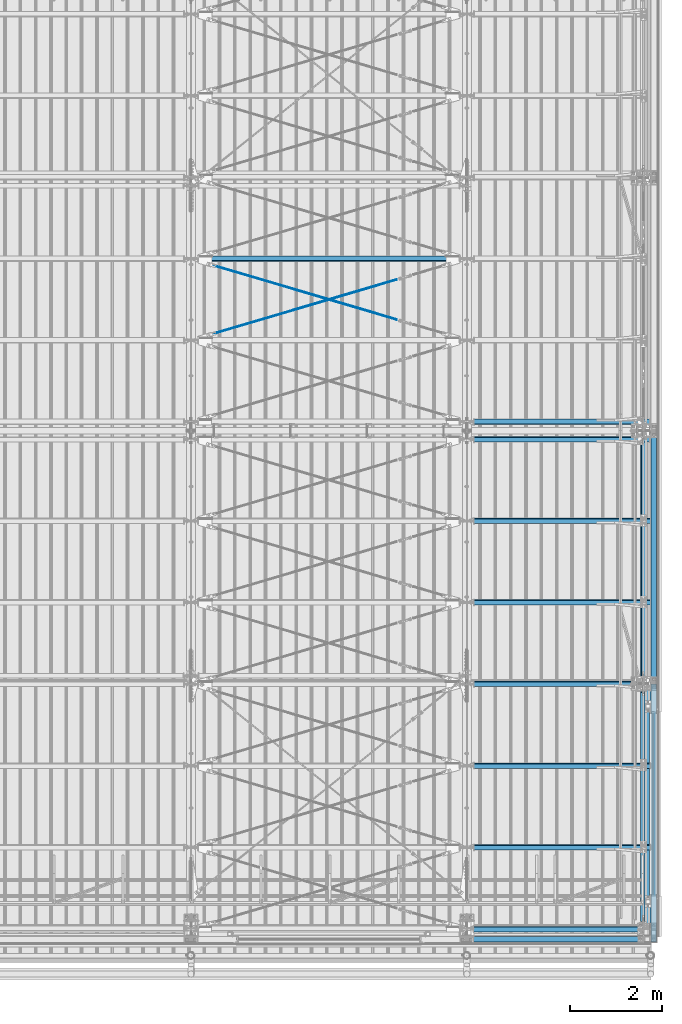
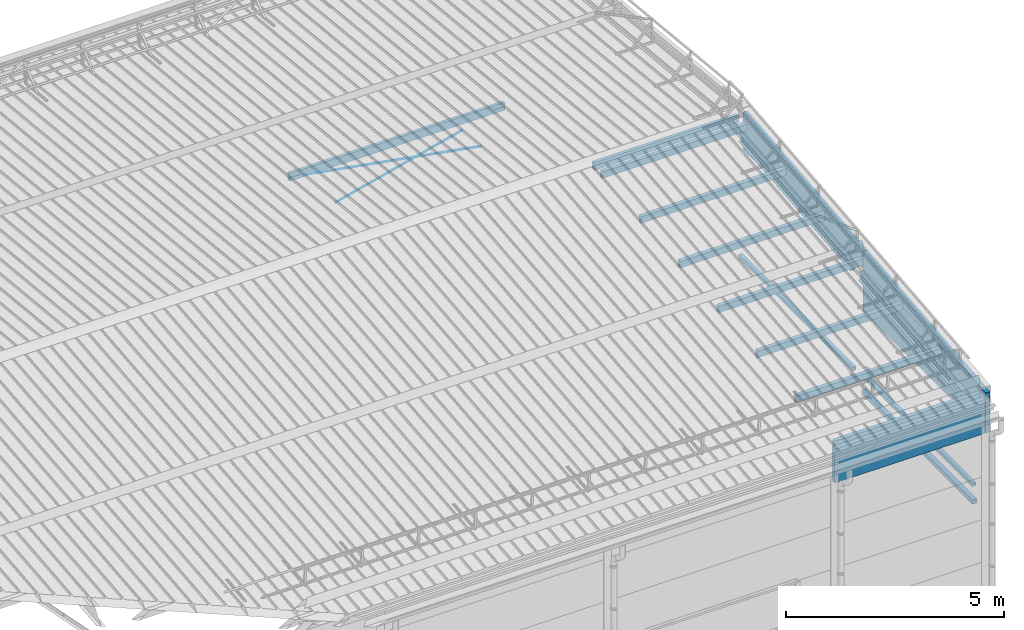
# One storey, part 282 of 709: 20 beams, 4 openings, 20 elements without a shape of their own.
"""IFC4 building model written with IfcOpenShell, lengths in millimetres."""

import ifcopenshell
import ifcopenshell.guid

model = None  # the IFC model being written
_history = None  # IfcOwnerHistory: only IFC2X3 demands one
_inside = {}  # id of a spatial element -> (the spatial element, [elements in it])
_under = {}  # id of a project, library or spatial element -> (it, [spatial elements below it])
_declared = {}  # id of a project -> (the project, [libraries it declares])
_typed = {}  # id of a type object -> (the type object, [elements of that type])
_made_of = {}  # id of a material, layer set ... -> (it, [elements and type objects made of it])


def new_model(schema):
    """Start an empty IFC model of exactly this schema.

    Asked for "IFC4X3", IfcOpenShell would pick the latest addendum, in which some entities
    have other attributes; the version numbers below select the first issue.
    IFC2X3 requires an IfcOwnerHistory on every rooted entity: one is made here for all.
    """
    global model, _history
    if schema == "IFC4X3":
        model = ifcopenshell.file(schema_version=(4, 3, 0, 0))
    else:
        model = ifcopenshell.file(schema=schema)
    _inside.clear()
    _under.clear()
    _declared.clear()
    _typed.clear()
    _made_of.clear()
    _history = None
    if model.schema == "IFC2X3":
        org = make("IfcOrganization", Name="unknown")
        user = make(
            "IfcPersonAndOrganization",
            ThePerson=make("IfcPerson", FamilyName="unknown"),
            TheOrganization=org,
        )
        app = make(
            "IfcApplication",
            ApplicationDeveloper=org,
            Version="unknown",
            ApplicationFullName="unknown",
            ApplicationIdentifier="unknown",
        )
        _history = make(
            "IfcOwnerHistory",
            OwningUser=user,
            OwningApplication=app,
            ChangeAction="ADDED",
            CreationDate=0,
        )
    return model


def make(cls, **values):
    """One entity of the class cls with the attributes given. An attribute that is None is left unset."""
    return model.create_entity(
        cls, **{name: value for name, value in values.items() if value is not None}
    )


def rooted(cls, **values):
    """An entity with a GlobalId (a new one), such as an element, a storey or a relation."""
    return make(cls, GlobalId=ifcopenshell.guid.new(), OwnerHistory=_history, **values)


def si_unit(unit_type, name, prefix=None):
    """IfcSIUnit, for example si_unit("LENGTHUNIT", "METRE", prefix="MILLI")."""
    return make("IfcSIUnit", UnitType=unit_type, Prefix=prefix, Name=name)


def assignment(units):
    """IfcUnitAssignment: the units of a project."""
    return None if units is None else make("IfcUnitAssignment", Units=units)


def point(xyz):
    """IfcCartesianPoint."""
    return None if xyz is None else make("IfcCartesianPoint", Coordinates=xyz)


def direction(xyz):
    """IfcDirection."""
    return None if xyz is None else make("IfcDirection", DirectionRatios=xyz)


def frame(location, z_axis=None, x_axis=None):
    """IfcAxis2Placement3D, a coordinate frame: its origin and axes. An axis left out is left unset."""
    return make(
        "IfcAxis2Placement3D",
        Location=point(location),
        Axis=direction(z_axis),
        RefDirection=direction(x_axis),
    )


def origin_with_axes():
    """The frame at (0, 0, 0) with the z axis (0, 0, 1) and the x axis (1, 0, 0) written out."""
    return frame((0.0, 0.0, 0.0), z_axis=(0.0, 0.0, 1.0), x_axis=(1.0, 0.0, 0.0))


def place(relative_to, where):
    """IfcLocalPlacement: puts the frame where relative to a parent placement (None: the world)."""
    return make(
        "IfcLocalPlacement", PlacementRelTo=relative_to, RelativePlacement=where
    )


def context(
    kind, dimensions, precision=None, world=None, true_north=None, identifier=None
):
    """IfcGeometricRepresentationContext, for example the 3D "Model" context."""
    return make(
        "IfcGeometricRepresentationContext",
        ContextIdentifier=identifier,
        ContextType=kind,
        CoordinateSpaceDimension=dimensions,
        Precision=precision,
        WorldCoordinateSystem=world,
        TrueNorth=true_north,
    )


def subcontext(parent, identifier, kind, view, scale=None):
    """IfcGeometricRepresentationSubContext, for example "Body" below "Model"."""
    return make(
        "IfcGeometricRepresentationSubContext",
        ContextIdentifier=identifier,
        ContextType=kind,
        ParentContext=parent,
        TargetScale=scale,
        TargetView=view,
    )


def project(units=None, contexts=None):
    """IfcProject with its units and contexts."""
    return rooted(
        "IfcProject",
        Name="project",
        RepresentationContexts=contexts,
        UnitsInContext=assignment(units),
    )


def spatial(cls, under=None, at=None, **own):
    """A site, building, storey or space (cls), placed at a placement, below another one or the project."""
    s = rooted(cls, ObjectPlacement=at, **own)
    if under is not None:
        _under.setdefault(under.id(), (under, []))[1].append(s)
    return s


def point_list(points):
    """IfcCartesianPointList2D or 3D."""
    cls = (
        "IfcCartesianPointList2D" if len(points[0]) == 2 else "IfcCartesianPointList3D"
    )
    return make(cls, CoordList=points)


def line(*indices):
    """IfcLineIndex: a straight run through numbered points of an indexed curve."""
    return model.create_entity("IfcLineIndex", indices)


def indexed_curve(points, segments=None, self_intersect=None):
    """IfcIndexedPolyCurve: lines and arcs through numbered points (the first is 1)."""
    return make(
        "IfcIndexedPolyCurve",
        Points=point_list(points),
        Segments=segments,
        SelfIntersect=self_intersect,
    )


def outline(outer, holes=None, kind="AREA"):
    """IfcArbitraryClosedProfileDef: a profile drawn as a closed curve; with holes, ...WithVoids."""
    if holes is None:
        return make("IfcArbitraryClosedProfileDef", ProfileType=kind, OuterCurve=outer)
    return make(
        "IfcArbitraryProfileDefWithVoids",
        ProfileType=kind,
        OuterCurve=outer,
        InnerCurves=holes,
    )


def extrude(swept, where, along, depth):
    """IfcExtrudedAreaSolid: the profile swept, set in the frame where, extruded along a direction by depth."""
    return make(
        "IfcExtrudedAreaSolid",
        SweptArea=swept,
        Position=where,
        ExtrudedDirection=direction(along),
        Depth=depth,
    )


def polygons(points, faces, closed=None, point_numbers=None):
    """IfcPolygonalFaceSet: a face is its outer loop, then its inner loops; points numbered from 1."""
    made = []
    for loops in faces:
        if len(loops) == 1:
            made.append(make("IfcIndexedPolygonalFace", CoordIndex=loops[0]))
        else:
            made.append(
                make(
                    "IfcIndexedPolygonalFaceWithVoids",
                    CoordIndex=loops[0],
                    InnerCoordIndices=loops[1:],
                )
            )
    return make(
        "IfcPolygonalFaceSet",
        Coordinates=point_list(points),
        Closed=closed,
        Faces=made,
        PnIndex=point_numbers,
    )


def shape(context_of_items, identifier, shape_type, items):
    """IfcShapeRepresentation: the items that make up one representation, for example the "Body"."""
    return make(
        "IfcShapeRepresentation",
        ContextOfItems=context_of_items,
        RepresentationIdentifier=identifier,
        RepresentationType=shape_type,
        Items=items,
    )


def material(Name=None, Category=None):
    """IfcMaterial."""
    return make("IfcMaterial", Name=Name, Category=Category)


def made_of(thing, what):
    """Note that an element or type object is made of a material, layer set ...; save() writes the relation."""
    if what is not None:
        _made_of.setdefault(what.id(), (what, []))[1].append(thing)
    return thing


def element(
    cls,
    number,
    at=None,
    inside=None,
    cuts=None,
    type_object=None,
    material=None,
    context=None,
    identifier="Body",
    shape_type=None,
    held_by="IfcProductDefinitionShape",
    body=None,
    shapes=None,
    **own,
):
    """One element of the class cls, such as IfcWall. Its Tag is "e" and its number.

    at: its placement. inside: the storey or other place that contains it. cuts: it is an
    opening in that element (IfcRelVoidsElement). A single representation is given by context,
    identifier, shape_type and body (its items); several are given by shapes. held_by: the class
    of the entity that holds the representations. save() writes the other relations.
    """
    e = rooted(cls, Tag="e%d" % number, ObjectPlacement=at, **own)
    if body is not None:
        shapes = [shape(context, identifier, shape_type, body)]
    if shapes is not None:
        e.Representation = make(held_by, Representations=shapes)
    if inside is not None:
        _inside.setdefault(inside.id(), (inside, []))[1].append(e)
    if cuts is not None:
        rooted(
            "IfcRelVoidsElement", RelatingBuildingElement=cuts, RelatedOpeningElement=e
        )
    if type_object is not None:
        _typed.setdefault(type_object.id(), (type_object, []))[1].append(e)
    return made_of(e, material)


def aggregate(whole, parts):
    """IfcRelAggregates: a whole, such as a stair, and the parts it consists of."""
    return rooted("IfcRelAggregates", RelatingObject=whole, RelatedObjects=parts)


def save(model, path):
    """Write the relations noted so far, then the file.

    IfcRelAggregates (storeys below a building ...), IfcRelContainedInSpatialStructure (elements
    in a storey), IfcRelDefinesByType, IfcRelAssociatesMaterial and IfcRelDeclares: one each for
    every whole, place, type object, material and project.
    """
    for whole, parts in _under.values():
        aggregate(whole, parts)
    for where, things in _inside.values():
        rooted(
            "IfcRelContainedInSpatialStructure",
            RelatedElements=things,
            RelatingStructure=where,
        )
    for kind, things in _typed.values():
        rooted("IfcRelDefinesByType", RelatedObjects=things, RelatingType=kind)
    for what, things in _made_of.values():
        rooted("IfcRelAssociatesMaterial", RelatedObjects=things, RelatingMaterial=what)
    for by, libraries in _declared.values():
        rooted("IfcRelDeclares", RelatingContext=by, RelatedDefinitions=libraries)
    model.write(path)


model = new_model("IFC4")

# Units and contexts
model_context = context("Model", 3, precision=0.2, world=origin_with_axes(), true_north=direction((0.0, 1.0)))
body_context = subcontext(model_context, "Body", "Model", "MODEL_VIEW")
reference_context = subcontext(model_context, "Reference", "Model", "MODEL_VIEW")
ifc_project = project(units=[si_unit("LENGTHUNIT", "METRE", prefix="MILLI"), si_unit("AREAUNIT", "SQUARE_METRE"), si_unit("VOLUMEUNIT", "CUBIC_METRE"), si_unit("MASSUNIT", "GRAM", prefix="KILO"), si_unit("TIMEUNIT", "SECOND"), si_unit("PLANEANGLEUNIT", "RADIAN"), si_unit("SOLIDANGLEUNIT", "STERADIAN"), si_unit("THERMODYNAMICTEMPERATUREUNIT", "DEGREE_CELSIUS"), si_unit("LUMINOUSINTENSITYUNIT", "LUMEN")], contexts=[model_context])

# Site, building, storey
site_placement = place(None, origin_with_axes())
site = spatial("IfcSite", under=ifc_project, at=site_placement, CompositionType="ELEMENT")
building_placement = place(site_placement, origin_with_axes())
building = spatial("IfcBuilding", under=site, at=building_placement, Name="Undefined", CompositionType="ELEMENT")
storey_placement = place(building_placement, origin_with_axes())
storey = spatial("IfcBuildingStorey", under=building, at=storey_placement, Name="Undefined", CompositionType="ELEMENT", Elevation=0.0)

# Assembly, beam
assembly_1_placement = place(storey_placement, frame((49837.5, 346.0, 6929.907), z_axis=(1.0, 0.0, 0.0), x_axis=(0.0, 0.9950371902, 0.099503719)))
assembly_1 = element("IfcElementAssembly", 1, at=assembly_1_placement, inside=storey)
ifc_material_1 = material(Name="C255-4", Category="STEEL")
beam_1_placement = place(assembly_1_placement, origin_with_axes())
beam_1 = element("IfcBeam", 2, at=beam_1_placement, material=ifc_material_1, ObjectType="451", context=body_context, shape_type="Tessellation", body=[
    polygons([(-15.12818, -124.0, -62.0), (-15.12818, -116.0, -62.0), (4996.83432, -116.0, -62.0), (4996.83432, -124.0, -62.0), (-15.12818, -116.0, -2.5), (4996.83432, -116.0, -2.5), (-15.12818, 116.0, -2.5), (4996.83432, 116.0, -2.5), (-15.12818, 116.0, -62.0), (4996.83432, 116.0, -62.0), (-15.12818, 124.0, -62.0), (4996.83432, 124.0, -62.0), (-15.12818, 124.0, 62.0), (4996.83432, 124.0, 62.0), (-15.12818, 116.0, 62.0), (4996.83432, 116.0, 62.0), (-15.12818, 116.0, 2.5), (4996.83432, 116.0, 2.5), (-15.12818, -116.0, 2.5), (4996.83432, -116.0, 2.5), (-15.12818, -116.0, 62.0), (4996.83432, -116.0, 62.0), (-15.12818, -124.0, 62.0), (4996.83432, -124.0, 62.0)], [[[1, 2, 3, 4]], [[2, 5, 6, 3]], [[5, 7, 8, 6]], [[7, 9, 10, 8]], [[9, 11, 12, 10]], [[11, 13, 14, 12]], [[13, 15, 16, 14]], [[15, 17, 18, 16]], [[17, 19, 20, 18]], [[19, 21, 22, 20]], [[21, 23, 24, 22]], [[23, 1, 4, 24]], [[6, 8, 10, 12, 14, 16, 18, 20, 22, 24, 4, 3]], [[23, 21, 19, 17, 15, 13, 11, 9, 7, 5, 2, 1]]], closed=True),
])
aggregate(assembly_1, [beam_1])

assembly_2_placement = place(storey_placement, frame((49837.5, 5500.0, 7445.307), z_axis=(1.0, 0.0, 0.0), x_axis=(0.0, 0.9950371902, 0.099503719)))
assembly_2 = element("IfcElementAssembly", 3, at=assembly_2_placement, inside=storey)
beam_2_placement = place(assembly_2_placement, origin_with_axes())
beam_2 = element("IfcBeam", 4, at=beam_2_placement, material=ifc_material_1, ObjectType="452", context=body_context, shape_type="Tessellation", body=[
    polygons([(5323.56002, 116.0, 2.5), (5323.56002, -116.0, 2.5), (5323.56002, -116.0, 62.0), (5323.56002, -124.0, 62.0), (5323.56002, -124.0, -62.0), (5323.56002, -116.0, -62.0), (5323.56002, -116.0, -2.5), (5323.56002, 116.0, -2.5), (5323.56002, 116.0, -62.0), (5323.56002, 124.0, -62.0), (5323.56002, 124.0, 62.0), (5323.56002, 116.0, 62.0), (166.87157, 124.0, 62.0), (166.87157, 116.0, 62.0), (166.87157, 116.0, 2.5), (166.87157, -116.0, 2.5), (166.87157, -116.0, 62.0), (166.87157, -124.0, 62.0), (166.87157, -124.0, -62.0), (166.87157, -116.0, -62.0), (166.87157, -116.0, -2.5), (166.87157, 116.0, -2.5), (166.87157, 116.0, -62.0), (166.87157, 124.0, -62.0)], [[[1, 2, 3, 4, 5, 6, 7, 8, 9, 10, 11, 12]], [[12, 11, 13, 14]], [[1, 12, 14, 15]], [[2, 1, 15, 16]], [[3, 2, 16, 17]], [[4, 3, 17, 18]], [[5, 4, 18, 19]], [[6, 5, 19, 20]], [[7, 6, 20, 21]], [[8, 7, 21, 22]], [[9, 8, 22, 23]], [[10, 9, 23, 24]], [[11, 10, 24, 13]], [[23, 22, 21, 20, 19, 18, 17, 16, 15, 14, 13, 24]]], closed=True),
])
aggregate(assembly_2, [beam_2])

assembly_3_placement = place(storey_placement, frame((49920.0, 80.0, 4610.0), z_axis=(0.0, 0.0, -1.0), x_axis=(0.0, 1.0, 0.0)))
assembly_3 = element("IfcElementAssembly", 5, at=assembly_3_placement, inside=storey)
ifc_material_2 = material(Name="C355", Category="STEEL")
beam_3_placement = place(assembly_3_placement, origin_with_axes())
beam_3 = element("IfcBeam", 6, at=beam_3_placement, material=ifc_material_2, ObjectType="494", context=body_context, shape_type="Tessellation", body=[
    polygons([(5277.5, 50.0, 50.0), (5277.5, 50.0, -50.0), (198.0, 50.0, -50.0), (198.0, 50.0, 50.0), (5277.5, -50.0, 50.0), (198.0, -50.0, 50.0), (5277.5, -50.0, -50.0), (198.0, -50.0, -50.0), (5277.5, 47.0, -47.0), (5277.5, 47.0, 47.0), (198.0, 47.0, 47.0), (198.0, 47.0, -47.0), (5277.5, -47.0, -47.0), (198.0, -47.0, -47.0), (5277.5, -47.0, 47.0), (198.0, -47.0, 47.0)], [[[1, 2, 3, 4]], [[5, 1, 4, 6]], [[7, 5, 6, 8]], [[2, 7, 8, 3]], [[1, 5, 7, 2], [10, 9, 13, 15]], [[9, 10, 11, 12]], [[13, 9, 12, 14]], [[15, 13, 14, 16]], [[10, 15, 16, 11]], [[8, 6, 4, 3], [14, 12, 11, 16]]], closed=True),
])
aggregate(assembly_3, [beam_3])

assembly_4_placement = place(storey_placement, frame((49940.0, 80.0, 4120.0), z_axis=(0.0, 0.0, -1.0), x_axis=(0.0, 1.0, 0.0)))
assembly_4 = element("IfcElementAssembly", 7, at=assembly_4_placement, inside=storey)
ifc_material_3 = material(Name="C255", Category="STEEL")
beam_4_placement = place(assembly_4_placement, origin_with_axes())
beam_4 = element("IfcBeam", 8, at=beam_4_placement, material=ifc_material_3, ObjectType="531", context=body_context, shape_type="Tessellation", body=[
    polygons([(5277.5, 60.0, 60.0), (5277.5, 60.0, -60.0), (198.0, 60.0, -60.0), (198.0, 60.0, 60.0), (5277.5, -60.0, 60.0), (198.0, -60.0, 60.0), (5277.5, -60.0, -60.0), (198.0, -60.0, -60.0), (5277.5, 56.0, -56.0), (5277.5, 56.0, 56.0), (198.0, 56.0, 56.0), (198.0, 56.0, -56.0), (5277.5, -56.0, -56.0), (198.0, -56.0, -56.0), (5277.5, -56.0, 56.0), (198.0, -56.0, 56.0)], [[[1, 2, 3, 4]], [[5, 1, 4, 6]], [[7, 5, 6, 8]], [[2, 7, 8, 3]], [[1, 5, 7, 2], [10, 9, 13, 15]], [[9, 10, 11, 12]], [[13, 9, 12, 14]], [[15, 13, 14, 16]], [[10, 15, 16, 11]], [[8, 6, 4, 3], [14, 12, 11, 16]]], closed=True),
])
aggregate(assembly_4, [beam_4])

assembly_5_placement = place(storey_placement, frame((49851.0, 5500.0, 4610.0), z_axis=(0.0, 0.0, -1.0), x_axis=(0.0, 1.0, 0.0)))
assembly_5 = element("IfcElementAssembly", 9, at=assembly_5_placement, inside=storey)
beam_5_placement = place(assembly_5_placement, origin_with_axes())
beam_5 = element("IfcBeam", 10, at=beam_5_placement, material=ifc_material_2, ObjectType="512", context=body_context, shape_type="Tessellation", body=[
    polygons([(142.5, -47.0, -47.0), (142.5, -47.0, 47.0), (5357.5, -47.0, 47.0), (5357.5, -47.0, -47.0), (142.5, 47.0, 47.0), (5357.5, 47.0, 47.0), (142.5, 47.0, -47.0), (5357.5, 47.0, -47.0), (142.5, -50.0, -50.0), (142.5, 50.0, -50.0), (5357.5, 50.0, -50.0), (5357.5, -50.0, -50.0), (142.5, 50.0, 50.0), (5357.5, 50.0, 50.0), (142.5, -50.0, 50.0), (5357.5, -50.0, 50.0)], [[[1, 2, 3, 4]], [[2, 5, 6, 3]], [[5, 7, 8, 6]], [[7, 1, 4, 8]], [[9, 10, 11, 12]], [[10, 13, 14, 11]], [[13, 15, 16, 14]], [[15, 9, 12, 16]], [[14, 16, 12, 11], [6, 8, 4, 3]], [[15, 13, 10, 9], [7, 5, 2, 1]]], closed=True),
])
aggregate(assembly_5, [beam_5])

# Assembly, beam, voiding feature
assembly_6_placement = place(storey_placement, frame((40000.0, 12964.14591, 8040.08943), z_axis=(0.2847296511, -0.9538504697, 0.095385047), x_axis=(0.9586078582, 0.2833165921, -0.028331659)))
assembly_6 = element("IfcElementAssembly", 11, at=assembly_6_placement, inside=storey)
ifc_material_4 = material(Name="C355-5", Category="STEEL")
beam_6_placement = place(assembly_6_placement, origin_with_axes())
beam_6 = element("IfcBeam", 12, at=beam_6_placement, material=ifc_material_4, ObjectType="572", context=body_context, shape_type="Tessellation", body=[
    polygons([(4849.07659, 7.36122, 4.25), (4849.07659, 6.01041, 6.01041), (4849.07659, 4.25, 7.36122), (4849.07659, 2.19996, 8.21037), (4849.07659, 0.0, 8.5), (4849.07659, -2.19996, 8.21037), (4849.07659, -4.25, 7.36122), (4849.07659, -6.01041, 6.01041), (4849.07659, -7.36121, 4.25), (4849.07659, -8.21037, 2.19996), (4849.07659, -8.5, 0.0), (4849.07659, -8.21037, -2.19996), (4849.07659, -7.36121, -4.25), (4849.07659, -6.01041, -6.01041), (4849.07659, -4.25, -7.36122), (4849.07659, -2.19996, -8.21037), (4849.07659, 0.0, -8.5), (4849.07659, 2.19996, -8.21037), (4849.07659, 4.25, -7.36122), (4849.07659, 6.01041, -6.01041), (4849.07659, 7.36122, -4.25), (4849.07659, 8.21037, -2.19996), (4849.07659, 8.5, 0.0), (4849.07659, 8.21037, 2.19996), (4669.07659, 8.21037, 2.19996), (4669.07659, 7.36122, 4.25), (4669.07659, 6.01041, 6.01041), (4669.07659, 4.25, 7.36122), (4669.07659, 2.19996, 8.21037), (4669.07659, 0.0, 8.5), (4669.07659, -2.19996, 8.21037), (4669.07659, -4.25, 7.36122), (4669.07659, -6.01041, 6.01041), (4669.07659, -7.36121, 4.25), (4669.07659, -8.21037, 2.19996), (4669.07659, -8.5, 0.0), (4669.07659, -8.21037, -2.19996), (4669.07659, -7.36121, -4.25), (4669.07659, -6.01041, -6.01041), (4669.07659, -4.25, -7.36122), (4669.07659, -2.19996, -8.21037), (4669.07659, 0.0, -8.5), (4669.07659, 2.19996, -8.21037), (4669.07659, 4.25, -7.36122), (4669.07659, 6.01041, -6.01041), (4669.07659, 7.36122, -4.25), (4669.07659, 8.21037, -2.19996), (4669.07659, 8.5, 0.0), (4669.07659, 10.0, 0.0), (4669.07659, 9.65926, 2.58819), (4669.07659, 8.66025, 5.0), (4669.07659, 7.07107, 7.07107), (4669.07659, 5.0, 8.66025), (4669.07659, 2.58819, 9.65926), (4669.07659, 0.0, 10.0), (4669.07659, -2.58819, 9.65926), (4669.07659, -5.0, 8.66025), (4669.07659, -7.07107, 7.07107), (4669.07659, -8.66025, 5.0), (4669.07659, -9.65926, 2.58819), (4669.07659, -10.0, 0.0), (4669.07659, -9.65926, -2.58819), (4669.07659, -8.66025, -5.0), (4669.07659, -7.07107, -7.07107), (4669.07659, -5.0, -8.66025), (4669.07659, -2.58819, -9.65926), (4669.07659, 0.0, -10.0), (4669.07659, 2.58819, -9.65926), (4669.07659, 5.0, -8.66025), (4669.07659, 7.07107, -7.07107), (4669.07659, 8.66025, -5.0), (4669.07659, 9.65926, -2.58819), (483.68279, 2.58819, 9.65926), (483.68279, 5.0, 8.66025), (483.68279, 7.07107, 7.07107), (483.68279, 8.66025, 5.0), (483.68279, 9.65926, 2.58819), (483.68279, 10.0, 0.0), (483.68279, 9.65926, -2.58819), (483.68279, 8.66025, -5.0), (483.68279, 7.07107, -7.07107), (483.68279, 5.0, -8.66025), (483.68279, 2.58819, -9.65926), (483.68279, 0.0, -10.0), (483.68279, -2.58819, -9.65926), (483.68279, -5.0, -8.66025), (483.68279, -7.07107, -7.07107), (483.68279, -8.66025, -5.0), (483.68279, -9.65926, -2.58819), (483.68279, -10.0, 0.0), (483.68279, -9.65926, 2.58819), (483.68279, -8.66025, 5.0), (483.68279, -7.07107, 7.07107), (483.68279, -5.0, 8.66025), (483.68279, -2.58819, 9.65926), (483.68279, 0.0, 10.0)], [[[1, 2, 3, 4, 5, 6, 7, 8, 9, 10, 11, 12, 13, 14, 15, 16, 17, 18, 19, 20, 21, 22, 23, 24]], [[24, 25, 26, 1]], [[1, 26, 27, 2]], [[2, 27, 28, 3]], [[3, 28, 29, 4]], [[4, 29, 30, 5]], [[5, 30, 31, 6]], [[6, 31, 32, 7]], [[7, 32, 33, 8]], [[8, 33, 34, 9]], [[9, 34, 35, 10]], [[10, 35, 36, 11]], [[11, 36, 37, 12]], [[12, 37, 38, 13]], [[13, 38, 39, 14]], [[14, 39, 40, 15]], [[15, 40, 41, 16]], [[16, 41, 42, 17]], [[17, 42, 43, 18]], [[18, 43, 44, 19]], [[19, 44, 45, 20]], [[20, 45, 46, 21]], [[21, 46, 47, 22]], [[22, 47, 48, 23]], [[23, 48, 25, 24]], [[49, 50, 51, 52, 53, 54, 55, 56, 57, 58, 59, 60, 61, 62, 63, 64, 65, 66, 67, 68, 69, 70, 71, 72], [47, 46, 45, 44, 43, 42, 41, 40, 39, 38, 37, 36, 35, 34, 33, 32, 31, 30, 29, 28, 27, 26, 25, 48]], [[73, 74, 75, 76, 77, 78, 79, 80, 81, 82, 83, 84, 85, 86, 87, 88, 89, 90, 91, 92, 93, 94, 95, 96]], [[79, 78, 49, 72]], [[80, 79, 72, 71]], [[81, 80, 71, 70]], [[82, 81, 70, 69]], [[83, 82, 69, 68]], [[84, 83, 68, 67]], [[85, 84, 67, 66]], [[86, 85, 66, 65]], [[87, 86, 65, 64]], [[88, 87, 64, 63]], [[89, 88, 63, 62]], [[90, 89, 62, 61]], [[91, 90, 61, 60]], [[92, 91, 60, 59]], [[93, 92, 59, 58]], [[94, 93, 58, 57]], [[95, 94, 57, 56]], [[96, 95, 56, 55]], [[73, 96, 55, 54]], [[74, 73, 54, 53]], [[75, 74, 53, 52]], [[76, 75, 52, 51]], [[77, 76, 51, 50]], [[78, 77, 50, 49]]], closed=True),
])
voiding_feature_1_placement = place(beam_6_placement, frame((4849.07659, 0.0, 0.0), z_axis=(0.0, 1.0, 0.0), x_axis=(-1.0, 0.0, 0.0)))
element("IfcVoidingFeature", 13, at=voiding_feature_1_placement, cuts=beam_6, PredefinedType="HOLE", context=reference_context, identifier="Reference", shape_type="SolidModel", body=[
    extrude(outline(indexed_curve([(10.5, 0.0), (10.14222, 2.7176), (9.09327, 5.25), (7.42462, 7.42462), (5.25, 9.09327), (2.7176, 10.14222), (0.0, 10.5), (-2.7176, 10.14222), (-5.25, 9.09327), (-7.42462, 7.42462), (-9.09327, 5.25), (-10.14222, 2.7176), (-10.5, 0.0), (-10.14222, -2.7176), (-9.09327, -5.25), (-7.42462, -7.42462), (-5.25, -9.09327), (-2.7176, -10.14222), (0.0, -10.5), (2.7176, -10.14222), (5.25, -9.09327), (7.42462, -7.42462), (9.09327, -5.25), (10.14222, -2.7176)], segments=[line(1, 2, 3, 4, 5, 6, 7, 8, 9, 10, 11, 12, 13, 14, 15, 16, 17, 18, 19, 20, 21, 22, 23, 24, 1)])), frame((0.0, 0.0, 0.0), z_axis=(-1.0, 0.0, 0.0), x_axis=(0.0, 0.0, 1.0)), (0.0, 0.0, -1.0), 180.0),
])
aggregate(assembly_6, [beam_6])

assembly_7_placement = place(storey_placement, frame((40000.0, 14737.44615, 7862.7594), z_axis=(-0.2847296511, -0.9538504697, 0.095385047), x_axis=(0.9586078582, -0.2833165921, 0.028331659)))
assembly_7 = element("IfcElementAssembly", 14, at=assembly_7_placement, inside=storey)
beam_7_placement = place(assembly_7_placement, origin_with_axes())
beam_7 = element("IfcBeam", 15, at=beam_7_placement, material=ifc_material_4, ObjectType="572", context=body_context, shape_type="Tessellation", body=[
    polygons([(4849.07659, 7.36122, 4.25), (4849.07659, 6.01041, 6.01041), (4849.07659, 4.25, 7.36122), (4849.07659, 2.19996, 8.21037), (4849.07659, 0.0, 8.5), (4849.07659, -2.19996, 8.21037), (4849.07659, -4.25, 7.36122), (4849.07659, -6.01041, 6.01041), (4849.07659, -7.36121, 4.25), (4849.07659, -8.21037, 2.19996), (4849.07659, -8.5, 0.0), (4849.07659, -8.21037, -2.19996), (4849.07659, -7.36121, -4.25), (4849.07659, -6.01041, -6.01041), (4849.07659, -4.25, -7.36122), (4849.07659, -2.19996, -8.21037), (4849.07659, 0.0, -8.5), (4849.07659, 2.19996, -8.21037), (4849.07659, 4.25, -7.36122), (4849.07659, 6.01041, -6.01041), (4849.07659, 7.36122, -4.25), (4849.07659, 8.21037, -2.19996), (4849.07659, 8.5, 0.0), (4849.07659, 8.21037, 2.19996), (4669.07659, 8.21037, 2.19996), (4669.07659, 7.36122, 4.25), (4669.07659, 6.01041, 6.01041), (4669.07659, 4.25, 7.36122), (4669.07659, 2.19996, 8.21037), (4669.07659, 0.0, 8.5), (4669.07659, -2.19996, 8.21037), (4669.07659, -4.25, 7.36122), (4669.07659, -6.01041, 6.01041), (4669.07659, -7.36121, 4.25), (4669.07659, -8.21037, 2.19996), (4669.07659, -8.5, 0.0), (4669.07659, -8.21037, -2.19996), (4669.07659, -7.36121, -4.25), (4669.07659, -6.01041, -6.01041), (4669.07659, -4.25, -7.36122), (4669.07659, -2.19996, -8.21037), (4669.07659, 0.0, -8.5), (4669.07659, 2.19996, -8.21037), (4669.07659, 4.25, -7.36122), (4669.07659, 6.01041, -6.01041), (4669.07659, 7.36122, -4.25), (4669.07659, 8.21037, -2.19996), (4669.07659, 8.5, 0.0), (4669.07659, 10.0, 0.0), (4669.07659, 9.65926, 2.58819), (4669.07659, 8.66025, 5.0), (4669.07659, 7.07107, 7.07107), (4669.07659, 5.0, 8.66025), (4669.07659, 2.58819, 9.65926), (4669.07659, 0.0, 10.0), (4669.07659, -2.58819, 9.65926), (4669.07659, -5.0, 8.66025), (4669.07659, -7.07107, 7.07107), (4669.07659, -8.66025, 5.0), (4669.07659, -9.65926, 2.58819), (4669.07659, -10.0, 0.0), (4669.07659, -9.65926, -2.58819), (4669.07659, -8.66025, -5.0), (4669.07659, -7.07107, -7.07107), (4669.07659, -5.0, -8.66025), (4669.07659, -2.58819, -9.65926), (4669.07659, 0.0, -10.0), (4669.07659, 2.58819, -9.65926), (4669.07659, 5.0, -8.66025), (4669.07659, 7.07107, -7.07107), (4669.07659, 8.66025, -5.0), (4669.07659, 9.65926, -2.58819), (483.68279, 2.58819, 9.65926), (483.68279, 5.0, 8.66025), (483.68279, 7.07107, 7.07107), (483.68279, 8.66025, 5.0), (483.68279, 9.65926, 2.58819), (483.68279, 10.0, 0.0), (483.68279, 9.65926, -2.58819), (483.68279, 8.66025, -5.0), (483.68279, 7.07107, -7.07107), (483.68279, 5.0, -8.66025), (483.68279, 2.58819, -9.65926), (483.68279, 0.0, -10.0), (483.68279, -2.58819, -9.65926), (483.68279, -5.0, -8.66025), (483.68279, -7.07107, -7.07107), (483.68279, -8.66025, -5.0), (483.68279, -9.65926, -2.58819), (483.68279, -10.0, 0.0), (483.68279, -9.65926, 2.58819), (483.68279, -8.66025, 5.0), (483.68279, -7.07107, 7.07107), (483.68279, -5.0, 8.66025), (483.68279, -2.58819, 9.65926), (483.68279, 0.0, 10.0)], [[[1, 2, 3, 4, 5, 6, 7, 8, 9, 10, 11, 12, 13, 14, 15, 16, 17, 18, 19, 20, 21, 22, 23, 24]], [[24, 25, 26, 1]], [[1, 26, 27, 2]], [[2, 27, 28, 3]], [[3, 28, 29, 4]], [[4, 29, 30, 5]], [[5, 30, 31, 6]], [[6, 31, 32, 7]], [[7, 32, 33, 8]], [[8, 33, 34, 9]], [[9, 34, 35, 10]], [[10, 35, 36, 11]], [[11, 36, 37, 12]], [[12, 37, 38, 13]], [[13, 38, 39, 14]], [[14, 39, 40, 15]], [[15, 40, 41, 16]], [[16, 41, 42, 17]], [[17, 42, 43, 18]], [[18, 43, 44, 19]], [[19, 44, 45, 20]], [[20, 45, 46, 21]], [[21, 46, 47, 22]], [[22, 47, 48, 23]], [[23, 48, 25, 24]], [[49, 50, 51, 52, 53, 54, 55, 56, 57, 58, 59, 60, 61, 62, 63, 64, 65, 66, 67, 68, 69, 70, 71, 72], [47, 46, 45, 44, 43, 42, 41, 40, 39, 38, 37, 36, 35, 34, 33, 32, 31, 30, 29, 28, 27, 26, 25, 48]], [[73, 74, 75, 76, 77, 78, 79, 80, 81, 82, 83, 84, 85, 86, 87, 88, 89, 90, 91, 92, 93, 94, 95, 96]], [[79, 78, 49, 72]], [[80, 79, 72, 71]], [[81, 80, 71, 70]], [[82, 81, 70, 69]], [[83, 82, 69, 68]], [[84, 83, 68, 67]], [[85, 84, 67, 66]], [[86, 85, 66, 65]], [[87, 86, 65, 64]], [[88, 87, 64, 63]], [[89, 88, 63, 62]], [[90, 89, 62, 61]], [[91, 90, 61, 60]], [[92, 91, 60, 59]], [[93, 92, 59, 58]], [[94, 93, 58, 57]], [[95, 94, 57, 56]], [[96, 95, 56, 55]], [[73, 96, 55, 54]], [[74, 73, 54, 53]], [[75, 74, 53, 52]], [[76, 75, 52, 51]], [[77, 76, 51, 50]], [[78, 77, 50, 49]]], closed=True),
])
voiding_feature_2_placement = place(beam_7_placement, frame((4849.07659, 0.0, 0.0), z_axis=(0.0, 1.0, 0.0), x_axis=(-1.0, 0.0, 0.0)))
element("IfcVoidingFeature", 16, at=voiding_feature_2_placement, cuts=beam_7, PredefinedType="HOLE", context=reference_context, identifier="Reference", shape_type="SolidModel", body=[
    extrude(outline(indexed_curve([(10.5, 0.0), (10.14222, 2.7176), (9.09327, 5.25), (7.42462, 7.42462), (5.25, 9.09327), (2.7176, 10.14222), (0.0, 10.5), (-2.7176, 10.14222), (-5.25, 9.09327), (-7.42462, 7.42462), (-9.09327, 5.25), (-10.14222, 2.7176), (-10.5, 0.0), (-10.14222, -2.7176), (-9.09327, -5.25), (-7.42462, -7.42462), (-5.25, -9.09327), (-2.7176, -10.14222), (0.0, -10.5), (2.7176, -10.14222), (5.25, -9.09327), (7.42462, -7.42462), (9.09327, -5.25), (10.14222, -2.7176)], segments=[line(1, 2, 3, 4, 5, 6, 7, 8, 9, 10, 11, 12, 13, 14, 15, 16, 17, 18, 19, 20, 21, 22, 23, 24, 1)])), frame((0.0, 0.0, 0.0), z_axis=(-1.0, 0.0, 0.0), x_axis=(0.0, 0.0, 1.0)), (0.0, 0.0, -1.0), 180.0),
])
aggregate(assembly_7, [beam_7])

# Assembly, beam
assembly_8_placement = place(storey_placement, frame((46000.0, 159.95037, 7144.45915), z_axis=(0.0, 0.9950371902, 0.099503719), x_axis=(1.0, 0.0, 0.0)))
assembly_8 = element("IfcElementAssembly", 17, at=assembly_8_placement, inside=storey)
beam_8_placement = place(assembly_8_placement, origin_with_axes())
beam_8 = element("IfcBeam", 18, at=beam_8_placement, material=ifc_material_2, ObjectType="562", context=body_context, shape_type="Tessellation", body=[
    polygons([(145.0, -100.0, 50.0), (145.0, -100.0, -50.0), (3972.0, -100.0, -50.0), (3972.0, -100.0, 50.0), (145.0, 100.0, 50.0), (3972.0, 100.0, 50.0), (145.0, 100.0, -50.0), (3972.0, 100.0, -50.0), (145.0, -96.0, 46.0), (145.0, 96.0, 46.0), (3972.0, 96.0, 46.0), (3972.0, -96.0, 46.0), (145.0, -96.0, -46.0), (3972.0, -96.0, -46.0), (145.0, 96.0, -46.0), (3972.0, 96.0, -46.0)], [[[1, 2, 3, 4]], [[5, 1, 4, 6]], [[7, 5, 6, 8]], [[2, 7, 8, 3]], [[1, 5, 7, 2], [15, 10, 9, 13]], [[9, 10, 11, 12]], [[13, 9, 12, 14]], [[15, 13, 14, 16]], [[10, 15, 16, 11]], [[3, 8, 6, 4], [14, 12, 11, 16]]], closed=True),
])
aggregate(assembly_8, [beam_8])

assembly_9_placement = place(storey_placement, frame((46000.0, 1936.65012, 7322.12913), z_axis=(0.0, 0.9950371902, 0.099503719), x_axis=(1.0, 0.0, 0.0)))
assembly_9 = element("IfcElementAssembly", 19, at=assembly_9_placement, inside=storey)
beam_9_placement = place(assembly_9_placement, origin_with_axes())
beam_9 = element("IfcBeam", 20, at=beam_9_placement, material=ifc_material_2, ObjectType="563", context=body_context, shape_type="Tessellation", body=[
    polygons([(155.0, -100.0, 50.0), (155.0, -100.0, -50.0), (3992.0, -100.0, -50.0), (3992.0, -100.0, 50.0), (155.0, 100.0, 50.0), (3992.0, 100.0, 50.0), (155.0, 100.0, -50.0), (3992.0, 100.0, -50.0), (155.0, -96.0, 46.0), (155.0, 96.0, 46.0), (3992.0, 96.0, 46.0), (3992.0, -96.0, 46.0), (155.0, -96.0, -46.0), (3992.0, -96.0, -46.0), (155.0, 96.0, -46.0), (3992.0, 96.0, -46.0)], [[[1, 2, 3, 4]], [[5, 1, 4, 6]], [[7, 5, 6, 8]], [[2, 7, 8, 3]], [[1, 5, 7, 2], [15, 10, 9, 13]], [[9, 10, 11, 12]], [[13, 9, 12, 14]], [[15, 13, 14, 16]], [[10, 15, 16, 11]], [[3, 8, 6, 4], [14, 12, 11, 16]]], closed=True),
])
aggregate(assembly_9, [beam_9])

assembly_10_placement = place(storey_placement, frame((46000.0, 3713.34988, 7499.7991), z_axis=(0.0, 0.9950371902, 0.099503719), x_axis=(1.0, 0.0, 0.0)))
assembly_10 = element("IfcElementAssembly", 21, at=assembly_10_placement, inside=storey)
beam_10_placement = place(assembly_10_placement, origin_with_axes())
beam_10 = element("IfcBeam", 22, at=beam_10_placement, material=ifc_material_2, ObjectType="563", context=body_context, shape_type="Tessellation", body=[
    polygons([(155.0, -100.0, 50.0), (155.0, -100.0, -50.0), (3992.0, -100.0, -50.0), (3992.0, -100.0, 50.0), (155.0, 100.0, 50.0), (3992.0, 100.0, 50.0), (155.0, 100.0, -50.0), (3992.0, 100.0, -50.0), (155.0, -96.0, 46.0), (155.0, 96.0, 46.0), (3992.0, 96.0, 46.0), (3992.0, -96.0, 46.0), (155.0, -96.0, -46.0), (3992.0, -96.0, -46.0), (155.0, 96.0, -46.0), (3992.0, 96.0, -46.0)], [[[1, 2, 3, 4]], [[5, 1, 4, 6]], [[7, 5, 6, 8]], [[2, 7, 8, 3]], [[1, 5, 7, 2], [15, 10, 9, 13]], [[9, 10, 11, 12]], [[13, 9, 12, 14]], [[15, 13, 14, 16]], [[10, 15, 16, 11]], [[3, 8, 6, 4], [14, 12, 11, 16]]], closed=True),
])
aggregate(assembly_10, [beam_10])

assembly_11_placement = place(storey_placement, frame((46000.0, 5490.04963, 7677.46908), z_axis=(0.0, 0.9950371902, 0.099503719), x_axis=(1.0, 0.0, 0.0)))
assembly_11 = element("IfcElementAssembly", 23, at=assembly_11_placement, inside=storey)
beam_11_placement = place(assembly_11_placement, origin_with_axes())
beam_11 = element("IfcBeam", 24, at=beam_11_placement, material=ifc_material_2, ObjectType="564", context=body_context, shape_type="Tessellation", body=[
    polygons([(155.0, -100.0, 50.0), (155.0, -100.0, -50.0), (3972.0, -100.0, -50.0), (3972.0, -100.0, 50.0), (155.0, 100.0, 50.0), (3972.0, 100.0, 50.0), (155.0, 100.0, -50.0), (3972.0, 100.0, -50.0), (155.0, -96.0, 46.0), (155.0, 96.0, 46.0), (3972.0, 96.0, 46.0), (3972.0, -96.0, 46.0), (155.0, -96.0, -46.0), (3972.0, -96.0, -46.0), (155.0, 96.0, -46.0), (3972.0, 96.0, -46.0)], [[[1, 2, 3, 4]], [[5, 1, 4, 6]], [[7, 5, 6, 8]], [[2, 7, 8, 3]], [[1, 5, 7, 2], [15, 10, 9, 13]], [[9, 10, 11, 12]], [[13, 9, 12, 14]], [[15, 13, 14, 16]], [[10, 15, 16, 11]], [[3, 8, 6, 4], [14, 12, 11, 16]]], closed=True),
])
aggregate(assembly_11, [beam_11])

assembly_12_placement = place(storey_placement, frame((46000.0, 7263.34988, 7854.7991), z_axis=(0.0, 0.9950371902, 0.099503719), x_axis=(1.0, 0.0, 0.0)))
assembly_12 = element("IfcElementAssembly", 25, at=assembly_12_placement, inside=storey)
beam_12_placement = place(assembly_12_placement, origin_with_axes())
beam_12 = element("IfcBeam", 26, at=beam_12_placement, material=ifc_material_2, ObjectType="563", context=body_context, shape_type="Tessellation", body=[
    polygons([(155.0, -100.0, 50.0), (155.0, -100.0, -50.0), (3992.0, -100.0, -50.0), (3992.0, -100.0, 50.0), (155.0, 100.0, 50.0), (3992.0, 100.0, 50.0), (155.0, 100.0, -50.0), (3992.0, 100.0, -50.0), (155.0, -96.0, 46.0), (155.0, 96.0, 46.0), (3992.0, 96.0, 46.0), (3992.0, -96.0, 46.0), (155.0, -96.0, -46.0), (3992.0, -96.0, -46.0), (155.0, 96.0, -46.0), (3992.0, 96.0, -46.0)], [[[1, 2, 3, 4]], [[5, 1, 4, 6]], [[7, 5, 6, 8]], [[2, 7, 8, 3]], [[1, 5, 7, 2], [15, 10, 9, 13]], [[9, 10, 11, 12]], [[13, 9, 12, 14]], [[15, 13, 14, 16]], [[10, 15, 16, 11]], [[3, 8, 6, 4], [14, 12, 11, 16]]], closed=True),
])
aggregate(assembly_12, [beam_12])

assembly_13_placement = place(storey_placement, frame((46000.0, 9036.65012, 8032.12913), z_axis=(0.0, 0.9950371902, 0.099503719), x_axis=(1.0, 0.0, 0.0)))
assembly_13 = element("IfcElementAssembly", 27, at=assembly_13_placement, inside=storey)
beam_13_placement = place(assembly_13_placement, origin_with_axes())
beam_13 = element("IfcBeam", 28, at=beam_13_placement, material=ifc_material_2, ObjectType="563", context=body_context, shape_type="Tessellation", body=[
    polygons([(155.0, -100.0, 50.0), (155.0, -100.0, -50.0), (3992.0, -100.0, -50.0), (3992.0, -100.0, 50.0), (155.0, 100.0, 50.0), (3992.0, 100.0, 50.0), (155.0, 100.0, -50.0), (3992.0, 100.0, -50.0), (155.0, -96.0, 46.0), (155.0, 96.0, 46.0), (3992.0, 96.0, 46.0), (3992.0, -96.0, 46.0), (155.0, -96.0, -46.0), (3992.0, -96.0, -46.0), (155.0, 96.0, -46.0), (3992.0, 96.0, -46.0)], [[[1, 2, 3, 4]], [[5, 1, 4, 6]], [[7, 5, 6, 8]], [[2, 7, 8, 3]], [[1, 5, 7, 2], [15, 10, 9, 13]], [[9, 10, 11, 12]], [[13, 9, 12, 14]], [[15, 13, 14, 16]], [[10, 15, 16, 11]], [[3, 8, 6, 4], [14, 12, 11, 16]]], closed=True),
])
aggregate(assembly_13, [beam_13])

assembly_14_placement = place(storey_placement, frame((46000.0, 10809.95037, 8209.45915), z_axis=(0.0, 0.9950371902, 0.099503719), x_axis=(1.0, 0.0, 0.0)))
assembly_14 = element("IfcElementAssembly", 29, at=assembly_14_placement, inside=storey)
beam_14_placement = place(assembly_14_placement, origin_with_axes())
beam_14 = element("IfcBeam", 30, at=beam_14_placement, material=ifc_material_2, ObjectType="564", context=body_context, shape_type="Tessellation", body=[
    polygons([(155.0, -100.0, 50.0), (155.0, -100.0, -50.0), (3972.0, -100.0, -50.0), (3972.0, -100.0, 50.0), (155.0, 100.0, 50.0), (3972.0, 100.0, 50.0), (155.0, 100.0, -50.0), (3972.0, 100.0, -50.0), (155.0, -96.0, 46.0), (155.0, 96.0, 46.0), (3972.0, 96.0, 46.0), (3972.0, -96.0, 46.0), (155.0, -96.0, -46.0), (3972.0, -96.0, -46.0), (155.0, 96.0, -46.0), (3972.0, 96.0, -46.0)], [[[1, 2, 3, 4]], [[5, 1, 4, 6]], [[7, 5, 6, 8]], [[2, 7, 8, 3]], [[1, 5, 7, 2], [15, 10, 9, 13]], [[9, 10, 11, 12]], [[13, 9, 12, 14]], [[15, 13, 14, 16]], [[10, 15, 16, 11]], [[3, 8, 6, 4], [14, 12, 11, 16]]], closed=True),
])
aggregate(assembly_14, [beam_14])

assembly_15_placement = place(storey_placement, frame((50000.0, 11190.04963, 8209.45915), z_axis=(0.0, -0.9950371902, 0.099503719), x_axis=(-1.0, 0.0, 0.0)))
assembly_15 = element("IfcElementAssembly", 31, at=assembly_15_placement, inside=storey)
beam_15_placement = place(assembly_15_placement, origin_with_axes())
beam_15 = element("IfcBeam", 32, at=beam_15_placement, material=ifc_material_2, ObjectType="564", context=body_context, shape_type="Tessellation", body=[
    polygons([(3845.0, 100.0, 50.0), (3845.0, 100.0, -50.0), (28.0, 100.0, -50.0), (28.0, 100.0, 50.0), (3845.0, -100.0, 50.0), (28.0, -100.0, 50.0), (3845.0, -100.0, -50.0), (28.0, -100.0, -50.0), (3845.0, 96.0, -46.0), (3845.0, 96.0, 46.0), (28.0, 96.0, 46.0), (28.0, 96.0, -46.0), (3845.0, -96.0, -46.0), (28.0, -96.0, -46.0), (3845.0, -96.0, 46.0), (28.0, -96.0, 46.0)], [[[1, 2, 3, 4]], [[5, 1, 4, 6]], [[7, 5, 6, 8]], [[2, 7, 8, 3]], [[1, 5, 7, 2], [10, 9, 13, 15]], [[9, 10, 11, 12]], [[13, 9, 12, 14]], [[15, 13, 14, 16]], [[10, 15, 16, 11]], [[8, 6, 4, 3], [14, 12, 11, 16]]], closed=True),
])
aggregate(assembly_15, [beam_15])

# Assembly, beam, voiding features
assembly_16_placement = place(storey_placement, frame((46000.0, 14736.65012, 7854.7991), z_axis=(0.0, -0.9950371902, 0.099503719), x_axis=(-1.0, 0.0, 0.0)))
assembly_16 = element("IfcElementAssembly", 33, at=assembly_16_placement, inside=storey)
beam_16_placement = place(assembly_16_placement, origin_with_axes())
beam_16 = element("IfcBeam", 34, at=beam_16_placement, material=ifc_material_2, ObjectType="566", context=body_context, shape_type="Tessellation", body=[
    polygons([(457.3028, -5.0, 50.0), (457.3028, -5.0, 46.0), (155.0, -5.0, 46.0), (155.0, -5.0, 50.0), (457.3028, 5.0, 50.0), (457.3028, 5.0, 46.0), (155.0, 5.0, 50.0), (155.0, 5.0, 46.0), (457.3028, -5.0, -46.0), (457.3028, -5.0, -50.0), (155.0, -5.0, -50.0), (155.0, -5.0, -46.0), (457.3028, 5.0, -46.0), (457.3028, 5.0, -50.0), (155.0, 5.0, -46.0), (155.0, 5.0, -50.0), (155.0, 96.0, 46.0), (155.0, 96.0, -46.0), (5845.0, 96.0, -46.0), (5845.0, 96.0, 46.0), (155.0, 100.0, -50.0), (5845.0, 100.0, -50.0), (5845.0, 5.0, -50.0), (5542.6972, 5.0, -50.0), (5542.6972, -5.0, -50.0), (5845.0, -5.0, -50.0), (5845.0, -100.0, -50.0), (155.0, -100.0, -50.0), (5845.00055, 5.0, -46.0), (5542.6972, 5.0, -46.0), (5542.6972, -5.0, -46.0), (5845.0, -5.0, -46.0), (155.0, -96.0, -46.0), (155.0, -96.0, 46.0), (5845.0, -96.0, 46.0), (5845.0, -96.0, -46.0), (5542.6972, -5.0, 50.0), (5542.6972, -5.0, 46.0), (5542.6972, 5.0, 46.0), (5542.6972, 5.0, 50.0), (5845.0, -5.0, 50.0), (5845.0, -5.0, 46.0), (5845.0, -100.0, 50.0), (155.0, -100.0, 50.0), (5845.0, 5.0, 46.0), (5845.00055, 5.0, 50.0), (5845.0, 100.0, 50.0), (155.0, 100.0, 50.0)], [[[1, 2, 3, 4]], [[5, 6, 2, 1]], [[7, 8, 6, 5]], [[9, 10, 11, 12]], [[13, 14, 10, 9]], [[15, 16, 14, 13]], [[17, 18, 19, 20]], [[21, 22, 23, 24, 25, 26, 27, 28, 11, 10, 14, 16]], [[29, 30, 24, 23]], [[31, 25, 24, 30]], [[32, 26, 25, 31]], [[33, 34, 35, 36]], [[37, 38, 39, 40]], [[41, 42, 38, 37]], [[43, 27, 26, 32, 36, 35, 42, 41]], [[44, 28, 27, 43]], [[34, 33, 12, 11, 28, 44, 4, 3]], [[17, 20, 45, 39, 38, 42, 35, 34, 3, 2, 6, 8]], [[46, 40, 39, 45]], [[20, 19, 29, 23, 22, 47, 46, 45]], [[21, 48, 47, 22]], [[4, 44, 43, 41, 37, 40, 46, 47, 48, 7, 5, 1]], [[48, 21, 16, 15, 18, 17, 8, 7]], [[12, 33, 36, 32, 31, 30, 29, 19, 18, 15, 13, 9]]], closed=True),
])
voiding_feature_3_placement = place(beam_16_placement, frame((5845.00055, 0.0, -92.98165), z_axis=(0.0, -1.0, 0.0), x_axis=(0.0, 0.0, 1.0)))
element("IfcVoidingFeature", 35, at=voiding_feature_3_placement, cuts=beam_16, Name="PLATE", PredefinedType="HOLE", context=reference_context, identifier="Reference", shape_type="SolidModel", body=[
    extrude(outline(indexed_curve([(0.0, 0.0), (185.9633, 0.0), (268.14324, 276.67769), (181.86854, 302.30336), (4.09476, 302.30336), (-82.17995, 276.67769)], segments=[line(1, 2, 3, 4, 5, 6, 1)])), frame((0.0, 0.0, 5.0), z_axis=(0.0, 0.0, 1.0), x_axis=(1.0, 0.0, 0.0)), (0.0, 0.0, -1.0), 10.0),
])
voiding_feature_4_placement = place(beam_16_placement, frame((154.99945, 0.0, 92.98165), z_axis=(0.0, -1.0, 0.0), x_axis=(0.0, 0.0, -1.0)))
element("IfcVoidingFeature", 36, at=voiding_feature_4_placement, cuts=beam_16, Name="PLATE", PredefinedType="HOLE", context=reference_context, identifier="Reference", shape_type="SolidModel", body=[
    extrude(outline(indexed_curve([(0.0, 0.0), (185.9633, 0.0), (268.14324, 276.67769), (181.86854, 302.30336), (4.09476, 302.30336), (-82.17995, 276.67769)], segments=[line(1, 2, 3, 4, 5, 6, 1)])), frame((0.0, 0.0, 5.0), z_axis=(0.0, 0.0, 1.0), x_axis=(1.0, 0.0, 0.0)), (0.0, 0.0, -1.0), 10.0),
])
aggregate(assembly_16, [beam_16])

# Assembly, beam
assembly_17_placement = place(storey_placement, frame((46010.0, -60.0, 6845.0), z_axis=(0.0, 0.0, -1.0), x_axis=(1.0, 0.0, 0.0)))
assembly_17 = element("IfcElementAssembly", 37, at=assembly_17_placement, inside=storey)
ifc_material_5 = material(Name="Insulation", Category="Insulation")
beam_17_placement = place(assembly_17_placement, origin_with_axes())
beam_17 = element("IfcBeam", 38, at=beam_17_placement, material=ifc_material_5, ObjectType="P-103", context=body_context, shape_type="Tessellation", body=[
    polygons([(0.0, 60.0, 595.0), (0.0, -60.0, 595.0), (3970.0, -60.0, 595.0), (3970.0, 60.0, 595.0), (3970.0, 60.0, -351.923), (0.0, 60.0, -351.923), (0.0, -60.0, -351.923), (3970.0, -60.0, -351.923)], [[[1, 2, 3, 4]], [[1, 4, 5, 6]], [[2, 1, 6, 7]], [[3, 2, 7, 8]], [[4, 3, 8, 5]], [[7, 6, 5, 8]]], closed=True),
])
aggregate(assembly_17, [beam_17])

assembly_18_placement = place(storey_placement, frame((50060.0, -120.0, 6845.0), z_axis=(0.0, 0.0, -1.0), x_axis=(0.0, 1.0, 0.0)))
assembly_18 = element("IfcElementAssembly", 39, at=assembly_18_placement, inside=storey)
beam_18_placement = place(assembly_18_placement, origin_with_axes())
beam_18 = element("IfcBeam", 40, at=beam_18_placement, material=ifc_material_5, ObjectType="P-131", context=body_context, shape_type="Tessellation", body=[
    polygons([(0.0, 60.0, 595.0), (0.0, -60.0, 595.0), (5610.0, -60.0, 595.0), (5610.0, 60.0, 595.0), (5610.0, -60.0, -595.0), (5610.0, 60.0, -595.0), (723.29, 60.0, -595.0), (0.0, 60.0, -522.671), (0.0, -60.0, -522.671), (723.29, -60.0, -595.0)], [[[1, 2, 3, 4]], [[4, 3, 5, 6]], [[1, 4, 6, 7, 8]], [[2, 1, 8, 9]], [[5, 3, 2, 9, 10]], [[6, 5, 10, 7]], [[9, 8, 7, 10]]], closed=True),
])
aggregate(assembly_18, [beam_18])

assembly_19_placement = place(storey_placement, frame((50060.0, -120.0, 8035.0), z_axis=(0.0, 0.0, -1.0), x_axis=(0.0, 1.0, 0.0)))
assembly_19 = element("IfcElementAssembly", 41, at=assembly_19_placement, inside=storey)
beam_19_placement = place(assembly_19_placement, origin_with_axes())
beam_19 = element("IfcBeam", 42, at=beam_19_placement, material=ifc_material_5, ObjectType="P-132", context=body_context, shape_type="Tessellation", body=[
    polygons([(5610.0, 60.0, 595.0), (5610.0, 60.0, 106.329), (723.29, 60.0, 595.0), (5610.0, -60.0, 595.0), (723.29, -60.0, 595.0), (5610.0, -60.0, 106.329)], [[[1, 2, 3]], [[4, 1, 3, 5]], [[4, 5, 6]], [[1, 4, 6, 2]], [[5, 3, 2, 6]]], closed=True),
])
aggregate(assembly_19, [beam_19])

assembly_20_placement = place(storey_placement, frame((50060.0, 5510.0, 8035.0), z_axis=(0.0, 0.0, -1.0), x_axis=(0.0, 1.0, 0.0)))
assembly_20 = element("IfcElementAssembly", 43, at=assembly_20_placement, inside=storey)
beam_20_placement = place(assembly_20_placement, origin_with_axes())
beam_20 = element("IfcBeam", 44, at=beam_20_placement, material=ifc_material_5, ObjectType="P-136", context=body_context, shape_type="Tessellation", body=[
    polygons([(0.0, 60.0, 595.0), (0.0, -60.0, 595.0), (5480.0, -60.0, 595.0), (5480.0, 60.0, 595.0), (5480.0, 60.0, -443.671), (0.0, 60.0, 104.329), (0.0, -60.0, 104.329), (5480.0, -60.0, -443.671)], [[[1, 2, 3, 4]], [[1, 4, 5, 6]], [[2, 1, 6, 7]], [[3, 2, 7, 8]], [[4, 3, 8, 5]], [[7, 6, 5, 8]]], closed=True),
])
aggregate(assembly_20, [beam_20])

save(model, "model.ifc")
